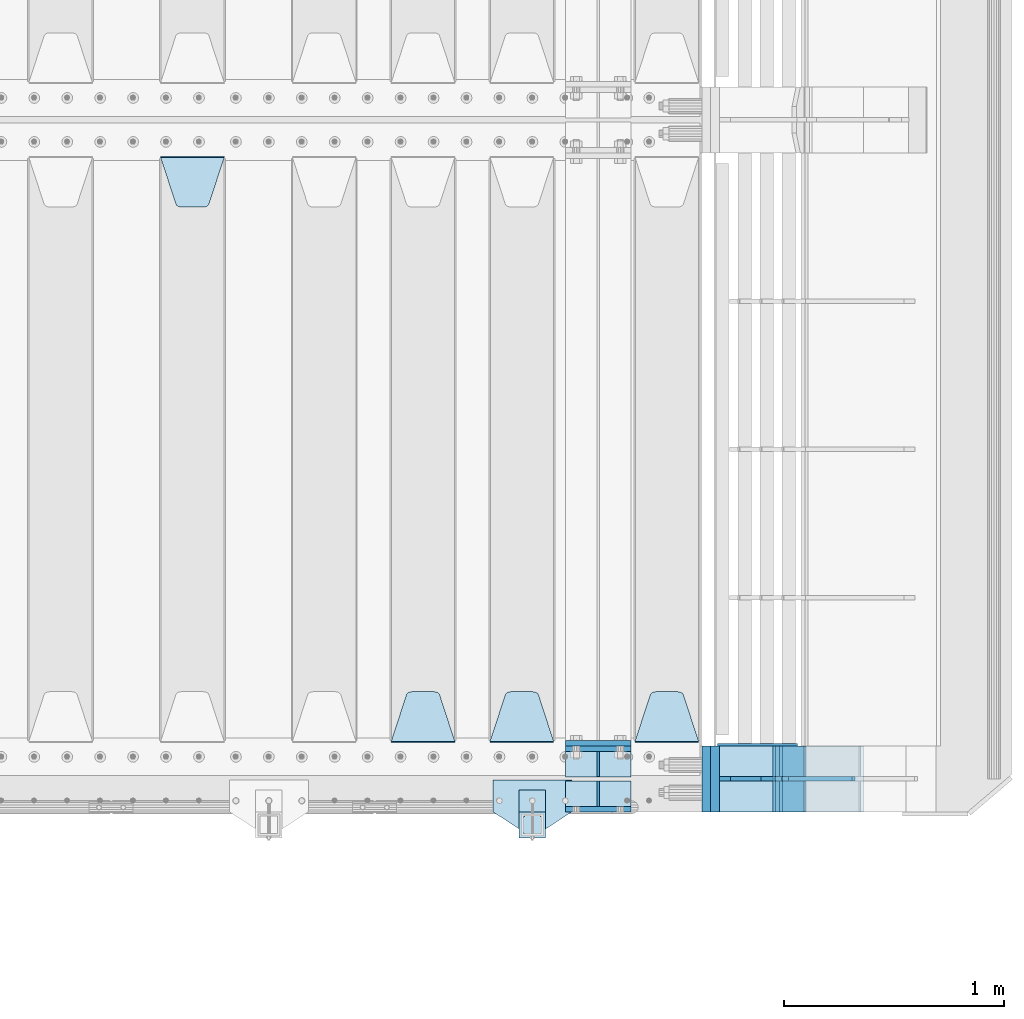
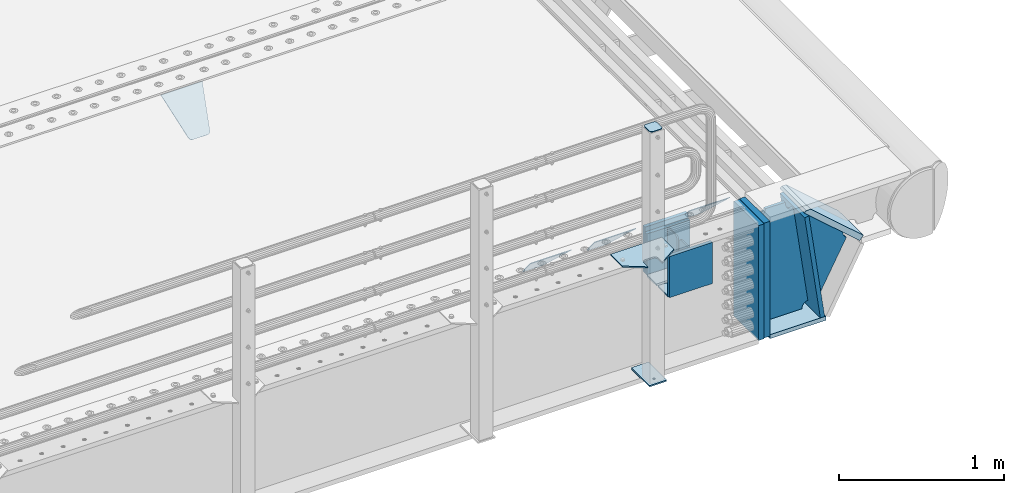
# One storey, part 219 of 242: 23 plates.
"""IFC2X3 building model written with IfcOpenShell, lengths in millimetres."""

from ifc_helpers import new_model, si_unit, frame, origin_with_axes, place, context, subcontext, project, spatial, faceted_brep, material, type_object, element, save


model = new_model("IFC2X3")

# Units and contexts
model_context = context("Model", 3, precision=1e-05, world=origin_with_axes())
body_context = subcontext(model_context, "Body", "Model", "MODEL_VIEW")
ifc_project = project(units=[si_unit("LENGTHUNIT", "METRE", prefix="MILLI"), si_unit("AREAUNIT", "SQUARE_METRE"), si_unit("VOLUMEUNIT", "CUBIC_METRE"), si_unit("MASSUNIT", "GRAM", prefix="KILO"), si_unit("TIMEUNIT", "SECOND"), si_unit("PLANEANGLEUNIT", "RADIAN"), si_unit("SOLIDANGLEUNIT", "STERADIAN"), si_unit("THERMODYNAMICTEMPERATUREUNIT", "DEGREE_CELSIUS"), si_unit("LUMINOUSINTENSITYUNIT", "LUMEN")], contexts=[model_context])

# Site, building, storey
site_placement = place(None, origin_with_axes())
site = spatial("IfcSite", under=ifc_project, at=site_placement, CompositionType="ELEMENT")
building_placement = place(site_placement, origin_with_axes())
building = spatial("IfcBuilding", under=site, at=building_placement, Name="Standard", CompositionType="ELEMENT")
storey_placement = place(building_placement, origin_with_axes())
storey = spatial("IfcBuildingStorey", under=building, at=storey_placement, Name="Undefined", CompositionType="ELEMENT", Elevation=0.0)

# Plates
ifc_material_1 = material(Name="STEEL/S355J2")
plate_type_1 = type_object("IfcPlateType", PredefinedType="NOTDEFINED")
plate_1_placement = place(storey_placement, frame((-22652.0, -24005.0, 5.00000000004911), z_axis=(0.0, -1.0, 0.0), x_axis=(-1.0, 0.0, 0.0)))
element("IfcPlate", 1, at=plate_1_placement, inside=storey, type_object=plate_type_1, material=ifc_material_1, context=body_context, shape_type="Brep", body=[
    faceted_brep([(0.0, -5.0, 0.0), (2.31396552408114e-06, -5.0, 145.0), (2.31396552408114e-06, 5.0, 145.0), (0.0, 5.0, 0.0), (130.0, -5.0, 230.0), (130.0, 5.0, 230.0), (130.0, -5.0, 180.0), (130.0, 5.0, 180.0), (130.48036798992, -5.0, 175.122741949595), (130.48036798992, 5.0, 175.122741949595), (131.903011687216, -5.0, 170.432914190871), (131.903011687216, 5.0, 170.432914190871), (134.213259692435, -5.0, 166.110744174512), (134.213259692435, 5.0, 166.110744174512), (137.322330470335, -5.0, 162.322330470335), (137.322330470335, 5.0, 162.322330470335), (141.110744174512, -5.0, 159.213259692435), (141.110744174512, 5.0, 159.213259692435), (145.432914190871, -5.0, 156.903011687216), (145.432914190871, 5.0, 156.903011687216), (150.122741949595, -5.0, 155.48036798992), (150.122741949595, 5.0, 155.48036798992), (155.0, -5.0, 155.0), (155.0, 5.0, 155.0), (205.0, -5.0, 155.0), (205.0, 5.0, 155.0), (209.877258050405, -5.0, 155.48036798992), (209.877258050405, 5.0, 155.48036798992), (214.567085809129, -5.0, 156.903011687216), (214.567085809129, 5.0, 156.903011687216), (218.889255825488, -5.0, 159.213259692435), (218.889255825488, 5.0, 159.213259692435), (222.677669529665, -5.0, 162.322330470335), (222.677669529665, 5.0, 162.322330470335), (225.786740307565, -5.0, 166.110744174512), (225.786740307565, 5.0, 166.110744174512), (228.096988312784, -5.0, 170.432914190871), (228.096988312784, 5.0, 170.432914190871), (229.51963201008, -5.0, 175.122741949595), (229.51963201008, 5.0, 175.122741949595), (230.0, -5.0, 180.0), (230.0, 5.0, 180.0), (230.0, -5.0, 230.0), (230.0, 5.0, 230.0), (360.0, -5.0, 145.0), (360.0, 5.0, 145.0), (360.0, -5.0, -7.27595761418343e-12), (360.0, 5.0, -7.27595761418343e-12)], [[[0, 1, 2, 3]], [[1, 4, 5, 2]], [[4, 6, 7, 5]], [[6, 8, 9, 7]], [[8, 10, 11, 9]], [[10, 12, 13, 11]], [[12, 14, 15, 13]], [[14, 16, 17, 15]], [[16, 18, 19, 17]], [[18, 20, 21, 19]], [[20, 22, 23, 21]], [[22, 24, 25, 23]], [[24, 26, 27, 25]], [[26, 28, 29, 27]], [[28, 30, 31, 29]], [[30, 32, 33, 31]], [[32, 34, 35, 33]], [[34, 36, 37, 35]], [[36, 38, 39, 37]], [[38, 40, 41, 39]], [[40, 42, 43, 41]], [[42, 44, 45, 43]], [[44, 46, 47, 45]], [[46, 0, 3, 47]], [[5, 7, 9, 11, 13, 15, 17, 19, 21, 23, 25, 27, 29, 31, 33, 35, 37, 39, 41, 43, 45, 47, 3, 2]], [[46, 44, 42, 40, 38, 36, 34, 32, 30, 28, 26, 24, 22, 20, 18, 16, 14, 12, 10, 8, 6, 4, 1, 0]]]),
])
plate_type_2 = type_object("IfcPlateType", PredefinedType="NOTDEFINED")
plate_2_placement = place(storey_placement, frame((-22772.0000000001, -24050.0000000002, -850.000000000002), z_axis=(0.0, -1.0, 0.0), x_axis=(-1.0, 0.0, 0.0)))
element("IfcPlate", 2, at=plate_2_placement, inside=storey, type_object=plate_type_2, material=ifc_material_1, context=body_context, shape_type="Brep", body=[
    faceted_brep([(53.6360389691836, -5.0, 176.363961030471), (53.6360389691836, 5.0, 176.363961030471), (59.9999999998618, 5.0, 178.999999999793), (59.9999999998618, -5.0, 178.999999999793), (66.3639610305399, 5.0, 176.363961030471), (66.3639610305399, -5.0, 176.363961030471), (68.9999999998618, 5.0, 169.999999999793), (68.9999999998618, -5.0, 169.999999999793), (66.3639610305399, 5.0, 163.636038969114), (66.3639610305399, -5.0, 163.636038969114), (59.9999999998618, 5.0, 160.999999999793), (59.9999999998618, -5.0, 160.999999999793), (53.6360389691836, 5.0, 163.636038969114), (53.6360389691836, -5.0, 163.636038969114), (50.9999999998618, 5.0, 169.999999999793), (50.9999999998618, -5.0, 169.999999999793), (120.0, -5.0, 0.0), (120.0, -5.0, 220.0), (0.0, -5.0, 220.0), (0.0, -5.0, 0.0), (0.0, 5.0, 0.0), (120.0, 5.0, 0.0), (120.0, 5.0, 220.0), (0.0, 5.0, 220.0)], [[[0, 1, 2, 3]], [[3, 2, 4, 5]], [[5, 4, 6, 7]], [[7, 6, 8, 9]], [[9, 8, 10, 11]], [[11, 10, 12, 13]], [[13, 12, 14, 15]], [[15, 14, 1, 0]], [[16, 17, 18, 19], [3, 5, 7, 9, 11, 13, 15, 0]], [[16, 19, 20, 21]], [[17, 16, 21, 22]], [[18, 17, 22, 23]], [[19, 18, 23, 20]], [[22, 21, 20, 23], [10, 8, 6, 4, 2, 1, 14, 12]]]),
])
plate_type_3 = type_object("IfcPlateType", PredefinedType="NOTDEFINED")
plate_3_placement = place(storey_placement, frame((-22876.0000000001, -24166.0000000002, 1012.50000000001), z_axis=(0.0, -1.0, 0.0), x_axis=(1.0, 0.0, 0.0)))
element("IfcPlate", 3, at=plate_3_placement, inside=storey, type_object=plate_type_3, material=ifc_material_1, context=body_context, shape_type="Brep", body=[
    faceted_brep([(0.0, -2.5, 19.0), (0.0, -2.5, 69.0), (0.0, 2.5, 69.0), (0.0, 2.5, 19.0), (0.476369668544066, -2.5, 73.2278977451715), (0.476369668544066, 2.5, 73.2278977451715), (1.88159150985302, -2.5, 77.2437910432345), (1.88159150985302, 2.5, 77.2437910432345), (4.14520183310742, -2.5, 80.8463062353148), (4.14520183310742, 2.5, 80.8463062353148), (7.15369376468516, -2.5, 83.8547981668926), (7.15369376468516, 2.5, 83.8547981668926), (10.7562089567655, -2.5, 86.118408490147), (10.7562089567655, 2.5, 86.118408490147), (14.7721022548285, -2.5, 87.5236303314559), (14.7721022548285, 2.5, 87.5236303314559), (19.0, -2.5, 88.0), (19.0, 2.5, 88.0), (69.0, -2.5, 88.0), (69.0, 2.5, 88.0), (73.2278977451715, -2.5, 87.5236303314559), (73.2278977451715, 2.5, 87.5236303314559), (77.2437910432345, -2.5, 86.118408490147), (77.2437910432345, 2.5, 86.118408490147), (80.8463062353148, -2.5, 83.8547981668926), (80.8463062353148, 2.5, 83.8547981668926), (83.8547981668926, -2.5, 80.8463062353148), (83.8547981668926, 2.5, 80.8463062353148), (86.118408490147, -2.5, 77.2437910432345), (86.118408490147, 2.5, 77.2437910432345), (87.5236303314559, -2.5, 73.2278977451715), (87.5236303314559, 2.5, 73.2278977451715), (88.0, -2.5, 69.0), (88.0, 2.5, 69.0), (88.0, -2.5, 19.0), (88.0, 2.5, 19.0), (87.5236303314559, -2.5, 14.7721022548285), (87.5236303314559, 2.5, 14.7721022548285), (86.118408490147, -2.5, 10.7562089567655), (86.118408490147, 2.5, 10.7562089567655), (83.8547981668926, -2.5, 7.15369376468516), (83.8547981668926, 2.5, 7.15369376468516), (80.8463062353148, -2.5, 4.14520183310742), (80.8463062353148, 2.5, 4.14520183310742), (77.2437910432345, -2.5, 1.88159150985302), (77.2437910432345, 2.5, 1.88159150985302), (73.2278977451715, -2.5, 0.476369668544066), (73.2278977451715, 2.5, 0.476369668544066), (69.0, -2.5, 0.0), (69.0, 2.5, 0.0), (19.0, -2.5, 0.0), (19.0, 2.5, 0.0), (14.7721022548285, -2.5, 0.476369668544066), (14.7721022548285, 2.5, 0.476369668544066), (10.7562089567655, -2.5, 1.88159150985302), (10.7562089567655, 2.5, 1.88159150985302), (7.15369376468516, -2.5, 4.14520183310742), (7.15369376468516, 2.5, 4.14520183310742), (4.14520183310742, -2.5, 7.15369376468516), (4.14520183310742, 2.5, 7.15369376468516), (1.88159150985302, -2.5, 10.7562089567655), (1.88159150985302, 2.5, 10.7562089567655), (0.476369668544066, -2.5, 14.7721022548285), (0.476369668544066, 2.5, 14.7721022548285)], [[[0, 1, 2, 3]], [[1, 4, 5, 2]], [[4, 6, 7, 5]], [[6, 8, 9, 7]], [[8, 10, 11, 9]], [[10, 12, 13, 11]], [[12, 14, 15, 13]], [[14, 16, 17, 15]], [[16, 18, 19, 17]], [[18, 20, 21, 19]], [[20, 22, 23, 21]], [[22, 24, 25, 23]], [[24, 26, 27, 25]], [[26, 28, 29, 27]], [[28, 30, 31, 29]], [[30, 32, 33, 31]], [[32, 34, 35, 33]], [[34, 36, 37, 35]], [[36, 38, 39, 37]], [[38, 40, 41, 39]], [[40, 42, 43, 41]], [[42, 44, 45, 43]], [[44, 46, 47, 45]], [[46, 48, 49, 47]], [[48, 50, 51, 49]], [[50, 52, 53, 51]], [[52, 54, 55, 53]], [[54, 56, 57, 55]], [[56, 58, 59, 57]], [[58, 60, 61, 59]], [[60, 62, 63, 61]], [[62, 0, 3, 63]], [[5, 7, 9, 11, 13, 15, 17, 19, 21, 23, 25, 27, 29, 31, 33, 35, 37, 39, 41, 43, 45, 47, 49, 51, 53, 55, 57, 59, 61, 63, 3, 2]], [[62, 60, 58, 56, 54, 52, 50, 48, 46, 44, 42, 40, 38, 36, 34, 32, 30, 28, 26, 24, 22, 20, 18, 16, 14, 12, 10, 8, 6, 4, 1, 0]]]),
])
plate_type_4 = type_object("IfcPlateType", PredefinedType="NOTDEFINED")
plate_4_placement = place(storey_placement, frame((-22772.0000000001, -24050.0000000002, -857.500000000002), z_axis=(0.0, -1.0, 0.0), x_axis=(-1.0, 0.0, 0.0)))
element("IfcPlate", 4, at=plate_4_placement, inside=storey, type_object=plate_type_4, material=ifc_material_1, context=body_context, shape_type="Brep", body=[
    faceted_brep([(0.0, -2.5, 0.0), (0.0, -2.5, 100.0), (0.0, 2.5, 100.0), (0.0, 2.5, 0.0), (120.0, -2.5, 100.0), (120.0, 2.5, 100.0), (120.0, -2.5, 0.0), (120.0, 2.5, 0.0)], [[[0, 1, 2, 3]], [[1, 4, 5, 2]], [[4, 6, 7, 5]], [[6, 0, 3, 7]], [[5, 7, 3, 2]], [[6, 4, 1, 0]]]),
])
ifc_material_2 = material(Name="STEEL/S355N")
plate_type_5 = type_object("IfcPlateType", PredefinedType="NOTDEFINED")
plate_5_placement = place(storey_placement, frame((-22682.0, -23837.5, -340.000000000044), z_axis=(0.0, 0.0, 1.0), x_axis=(1.0, 0.0, 0.0)))
element("IfcPlate", 5, at=plate_5_placement, inside=storey, type_object=plate_type_5, material=ifc_material_2, context=body_context, shape_type="Brep", body=[
    faceted_brep([(0.0, -12.5, 0.0), (9.27684595808387e-10, -12.5, 340.0), (9.27684595808387e-10, 12.5, 340.0), (0.0, 12.5, 0.0), (300.0, -12.5, 340.0), (300.0, 12.5, 340.0), (300.0, -12.5, 0.0), (300.0, 12.5, 0.0)], [[[0, 1, 2, 3]], [[1, 4, 5, 2]], [[4, 6, 7, 5]], [[6, 0, 3, 7]], [[5, 7, 3, 2]], [[6, 4, 1, 0]]]),
])
for number, where, z_axis, x_axis in (
    (6, (-22682.0, -24137.5, -339.99999999999), (0.0, 0.0, 1.0), (1.0, 0.0, 0.0)),
    (7, (-22682.0, -23862.5, -339.99999999999), (0.0, 0.0, 1.0), (1.0, 0.0, 0.0)),
):
    element("IfcPlate", number, at=place(storey_placement, frame(where, z_axis=z_axis, x_axis=x_axis)), inside=storey, type_object=plate_type_5, material=ifc_material_2, context=body_context, shape_type="Brep", body=[
        faceted_brep([(0.0, -12.5, 0.0), (0.0, -12.5, 305.0), (0.0, 12.5, 305.0), (0.0, 12.5, 0.0), (300.0, -12.5, 305.0), (300.0, 12.5, 305.0), (300.0, -12.5, 0.0), (300.0, 12.5, 0.0)], [[[0, 1, 2, 3]], [[1, 4, 5, 2]], [[4, 6, 7, 5]], [[6, 0, 3, 7]], [[5, 7, 3, 2]], [[6, 4, 1, 0]]]),
    ])
plate_type_6 = type_object("IfcPlateType", PredefinedType="NOTDEFINED")
plate_6_placement = place(storey_placement, frame((-22075.0, -23831.767766953, -1.76776695296758), z_axis=(0.0, 0.707106781186547, -0.707106781186548), x_axis=(-1.0, 0.0, 0.0)))
element("IfcPlate", 8, at=plate_6_placement, inside=storey, type_object=plate_type_6, material=ifc_material_2, context=body_context, shape_type="Brep", body=[
    faceted_brep([(0.0, -2.5, 0.0), (69.345504679477, -2.50000000000182, 300.171731424829), (69.345504679477, 2.5, 300.171731424829), (0.0, 2.5, 0.0), (70.9274061199576, -2.5, 304.897442415398), (70.9274061199576, 2.5, 304.897442415398), (73.3818627772307, -2.5, 309.234538108525), (73.3818627772307, 2.50000000000182, 309.234538108529), (76.6187032999551, -2.5, 313.023683126101), (76.6187032999551, 2.50000000000182, 313.023683126103), (80.5190132704993, -2.5, 316.12567259537), (80.5190132704993, 2.5, 316.12567259537), (84.9395038596849, -2.5, 318.426546230474), (84.9395038596849, 2.50000000000182, 318.426546230476), (89.7177759439219, -2.49999999999818, 319.841774983273), (89.7177759439219, 2.50000000000182, 319.841774983273), (94.678286292652, -2.5, 320.319366455076), (94.678286292652, 2.5, 320.319366455076), (195.321713707348, -2.5, 320.319366455076), (195.321713707348, 2.5, 320.319366455076), (200.282224056078, -2.5, 319.841774983272), (200.282224056078, 2.50000000000182, 319.841774983273), (205.060496140315, -2.5, 318.426546230474), (205.060496140315, 2.49999999999818, 318.426546230474), (209.480986729501, -2.49999999999818, 316.12567259537), (209.480986729501, 2.5, 316.12567259537), (213.381296700045, -2.5, 313.023683126101), (213.381296700045, 2.49999999999818, 313.023683126101), (216.618137222769, -2.5, 309.234538108525), (216.618137222769, 2.5, 309.234538108523), (219.072593880042, -2.49999999999818, 304.897442415398), (219.072593880042, 2.50000000000182, 304.897442415398), (220.654495320523, -2.50000000000182, 300.171731424829), (220.654495320523, 2.5, 300.171731424829), (290.0, -2.5, 0.0), (290.0, 2.5, -1.81898940354586e-12)], [[[0, 1, 2, 3]], [[1, 4, 5, 2]], [[4, 6, 7, 5]], [[6, 8, 9, 7]], [[8, 10, 11, 9]], [[10, 12, 13, 11]], [[12, 14, 15, 13]], [[14, 16, 17, 15]], [[16, 18, 19, 17]], [[18, 20, 21, 19]], [[20, 22, 23, 21]], [[22, 24, 25, 23]], [[24, 26, 27, 25]], [[26, 28, 29, 27]], [[28, 30, 31, 29]], [[30, 32, 33, 31]], [[32, 34, 35, 33]], [[34, 0, 3, 35]], [[5, 7, 9, 11, 13, 15, 17, 19, 21, 23, 25, 27, 29, 31, 33, 35, 3, 2]], [[34, 32, 30, 28, 26, 24, 22, 20, 18, 16, 14, 12, 10, 8, 6, 4, 1, 0]]]),
])
plate_7_placement = place(storey_placement, frame((-22735.0, -23831.767766953, -1.76776695296758), z_axis=(0.0, 0.707106781186547, -0.707106781186548), x_axis=(-1.0, 0.0, 0.0)))
element("IfcPlate", 9, at=plate_7_placement, inside=storey, type_object=plate_type_6, material=ifc_material_2, context=body_context, shape_type="Brep", body=[
    faceted_brep([(0.0, -2.5, 0.0), (69.345504679477, -2.50000000000182, 300.171731424829), (69.345504679477, 2.5, 300.171731424829), (0.0, 2.5, 0.0), (70.9274061199576, -2.5, 304.897442415398), (70.9274061199576, 2.5, 304.897442415398), (73.3818627772307, -2.5, 309.234538108525), (73.3818627772307, 2.50000000000182, 309.234538108529), (76.6187032999551, -2.5, 313.023683126101), (76.6187032999551, 2.50000000000182, 313.023683126103), (80.5190132704993, -2.5, 316.12567259537), (80.5190132704993, 2.5, 316.12567259537), (84.9395038596849, -2.5, 318.426546230474), (84.9395038596849, 2.50000000000182, 318.426546230476), (89.7177759439219, -2.49999999999818, 319.841774983273), (89.7177759439219, 2.50000000000182, 319.841774983273), (94.678286292652, -2.5, 320.319366455076), (94.678286292652, 2.5, 320.319366455076), (195.321713707348, -2.5, 320.319366455076), (195.321713707348, 2.5, 320.319366455076), (200.282224056078, -2.5, 319.841774983272), (200.282224056078, 2.50000000000182, 319.841774983273), (205.060496140315, -2.5, 318.426546230474), (205.060496140315, 2.49999999999818, 318.426546230474), (209.480986729501, -2.49999999999818, 316.12567259537), (209.480986729501, 2.5, 316.12567259537), (213.381296700045, -2.5, 313.023683126101), (213.381296700045, 2.49999999999818, 313.023683126101), (216.618137222769, -2.5, 309.234538108525), (216.618137222769, 2.5, 309.234538108523), (219.072593880042, -2.49999999999818, 304.897442415398), (219.072593880042, 2.50000000000182, 304.897442415398), (220.654495320523, -2.50000000000182, 300.171731424829), (220.654495320523, 2.5, 300.171731424829), (290.0, -2.5, 0.0), (290.0, 2.5, -1.81898940354586e-12)], [[[0, 1, 2, 3]], [[1, 4, 5, 2]], [[4, 6, 7, 5]], [[6, 8, 9, 7]], [[8, 10, 11, 9]], [[10, 12, 13, 11]], [[12, 14, 15, 13]], [[14, 16, 17, 15]], [[16, 18, 19, 17]], [[18, 20, 21, 19]], [[20, 22, 23, 21]], [[22, 24, 25, 23]], [[24, 26, 27, 25]], [[26, 28, 29, 27]], [[28, 30, 31, 29]], [[30, 32, 33, 31]], [[32, 34, 35, 33]], [[34, 0, 3, 35]], [[5, 7, 9, 11, 13, 15, 17, 19, 21, 23, 25, 27, 29, 31, 33, 35, 3, 2]], [[34, 32, 30, 28, 26, 24, 22, 20, 18, 16, 14, 12, 10, 8, 6, 4, 1, 0]]]),
])
plate_8_placement = place(storey_placement, frame((-23185.0, -23831.767766953, -1.76776695296758), z_axis=(0.0, 0.707106781186547, -0.707106781186548), x_axis=(-1.0, 0.0, 0.0)))
element("IfcPlate", 10, at=plate_8_placement, inside=storey, type_object=plate_type_6, material=ifc_material_2, context=body_context, shape_type="Brep", body=[
    faceted_brep([(0.0, -2.5, 0.0), (69.345504679477, -2.50000000000182, 300.171731424829), (69.345504679477, 2.5, 300.171731424829), (0.0, 2.5, 0.0), (70.9274061199576, -2.5, 304.897442415398), (70.9274061199576, 2.5, 304.897442415398), (73.3818627772307, -2.5, 309.234538108525), (73.3818627772307, 2.50000000000182, 309.234538108529), (76.6187032999551, -2.5, 313.023683126101), (76.6187032999551, 2.50000000000182, 313.023683126103), (80.5190132704993, -2.5, 316.12567259537), (80.5190132704993, 2.5, 316.12567259537), (84.9395038596849, -2.5, 318.426546230474), (84.9395038596849, 2.50000000000182, 318.426546230476), (89.7177759439219, -2.49999999999818, 319.841774983273), (89.7177759439219, 2.50000000000182, 319.841774983273), (94.678286292652, -2.5, 320.319366455076), (94.678286292652, 2.5, 320.319366455076), (195.321713707348, -2.5, 320.319366455076), (195.321713707348, 2.5, 320.319366455076), (200.282224056078, -2.5, 319.841774983272), (200.282224056078, 2.50000000000182, 319.841774983273), (205.060496140315, -2.5, 318.426546230474), (205.060496140315, 2.49999999999818, 318.426546230474), (209.480986729501, -2.49999999999818, 316.12567259537), (209.480986729501, 2.5, 316.12567259537), (213.381296700045, -2.5, 313.023683126101), (213.381296700045, 2.49999999999818, 313.023683126101), (216.618137222769, -2.5, 309.234538108525), (216.618137222769, 2.5, 309.234538108523), (219.072593880042, -2.49999999999818, 304.897442415398), (219.072593880042, 2.50000000000182, 304.897442415398), (220.654495320523, -2.50000000000182, 300.171731424829), (220.654495320523, 2.5, 300.171731424829), (290.0, -2.5, 0.0), (290.0, 2.5, -1.81898940354586e-12)], [[[0, 1, 2, 3]], [[1, 4, 5, 2]], [[4, 6, 7, 5]], [[6, 8, 9, 7]], [[8, 10, 11, 9]], [[10, 12, 13, 11]], [[12, 14, 15, 13]], [[14, 16, 17, 15]], [[16, 18, 19, 17]], [[18, 20, 21, 19]], [[20, 22, 23, 21]], [[22, 24, 25, 23]], [[24, 26, 27, 25]], [[26, 28, 29, 27]], [[28, 30, 31, 29]], [[30, 32, 33, 31]], [[32, 34, 35, 33]], [[34, 0, 3, 35]], [[5, 7, 9, 11, 13, 15, 17, 19, 21, 23, 25, 27, 29, 31, 33, 35, 3, 2]], [[34, 32, 30, 28, 26, 24, 22, 20, 18, 16, 14, 12, 10, 8, 6, 4, 1, 0]]]),
])
plate_9_placement = place(storey_placement, frame((-24525.0, -21168.232233044, -1.76776695296576), z_axis=(0.0, -0.707106781186547, -0.707106781186548), x_axis=(1.0, 0.0, 0.0)))
element("IfcPlate", 11, at=plate_9_placement, inside=storey, type_object=plate_type_6, material=ifc_material_2, context=body_context, shape_type="Brep", body=[
    faceted_brep([(0.0, -2.5, 0.0), (69.345504679477, -2.50000000000182, 300.171731424829), (69.345504679477, 2.5, 300.171731424829), (0.0, 2.5, 0.0), (70.9274061199576, -2.5, 304.897442415398), (70.9274061199576, 2.5, 304.897442415398), (73.3818627772307, -2.5, 309.234538108525), (73.3818627772307, 2.50000000000182, 309.234538108529), (76.6187032999551, -2.5, 313.023683126101), (76.6187032999551, 2.50000000000182, 313.023683126103), (80.5190132704993, -2.5, 316.12567259537), (80.5190132704993, 2.5, 316.12567259537), (84.9395038596849, -2.5, 318.426546230474), (84.9395038596849, 2.50000000000182, 318.426546230476), (89.7177759439219, -2.49999999999818, 319.841774983273), (89.7177759439219, 2.50000000000182, 319.841774983273), (94.678286292652, -2.5, 320.319366455076), (94.678286292652, 2.5, 320.319366455076), (195.321713707348, -2.5, 320.319366455076), (195.321713707348, 2.5, 320.319366455076), (200.282224056078, -2.5, 319.841774983272), (200.282224056078, 2.50000000000182, 319.841774983273), (205.060496140315, -2.5, 318.426546230474), (205.060496140315, 2.49999999999818, 318.426546230474), (209.480986729501, -2.49999999999818, 316.12567259537), (209.480986729501, 2.5, 316.12567259537), (213.381296700045, -2.5, 313.023683126101), (213.381296700045, 2.49999999999818, 313.023683126101), (216.618137222769, -2.5, 309.234538108525), (216.618137222769, 2.5, 309.234538108523), (219.072593880042, -2.49999999999818, 304.897442415398), (219.072593880042, 2.50000000000182, 304.897442415398), (220.654495320523, -2.50000000000182, 300.171731424829), (220.654495320523, 2.5, 300.171731424829), (290.0, -2.5, 0.0), (290.0, 2.5, -1.81898940354586e-12)], [[[0, 1, 2, 3]], [[1, 4, 5, 2]], [[4, 6, 7, 5]], [[6, 8, 9, 7]], [[8, 10, 11, 9]], [[10, 12, 13, 11]], [[12, 14, 15, 13]], [[14, 16, 17, 15]], [[16, 18, 19, 17]], [[18, 20, 21, 19]], [[20, 22, 23, 21]], [[22, 24, 25, 23]], [[24, 26, 27, 25]], [[26, 28, 29, 27]], [[28, 30, 31, 29]], [[30, 32, 33, 31]], [[32, 34, 35, 33]], [[34, 0, 3, 35]], [[5, 7, 9, 11, 13, 15, 17, 19, 21, 23, 25, 27, 29, 31, 33, 35, 3, 2]], [[34, 32, 30, 28, 26, 24, 22, 20, 18, 16, 14, 12, 10, 8, 6, 4, 1, 0]]]),
])
plate_type_7 = type_object("IfcPlateType", PredefinedType="NOTDEFINED")
plate_10_placement = place(storey_placement, frame((-21587.0011701109, -23850.0, -875.000000002935), z_axis=(0.0, -1.0, 0.0), x_axis=(-1.0, 0.0, 0.0)))
element("IfcPlate", 12, at=plate_10_placement, inside=storey, type_object=plate_type_7, material=ifc_material_2, context=body_context, shape_type="Brep", body=[
    faceted_brep([(0.0, -15.0, 0.0), (0.0, -15.0, 300.0), (0.0, 15.0, 300.0), (0.0, 15.0, 0.0), (393.0, -15.0, 300.0), (393.0, 15.0, 300.0), (393.0, -15.0, 0.0), (393.0, 15.0, 0.0)], [[[0, 1, 2, 3]], [[1, 4, 5, 2]], [[4, 6, 7, 5]], [[6, 0, 3, 7]], [[5, 7, 3, 2]], [[6, 4, 1, 0]]]),
])
plate_11_placement = place(storey_placement, frame((-21610.8519322773, -23849.999999999, -862.083788727077), z_axis=(-0.139173011053008, 0.0, 0.990268081377179), x_axis=(0.0, -1.0, 0.0)))
element("IfcPlate", 13, at=plate_11_placement, inside=storey, type_object=plate_type_7, material=ifc_material_2, context=body_context, shape_type="Brep", body=[
    faceted_brep([(1.00408215075731e-09, 14.9994702460535, -0.00376939767375006), (300.0, 15.0, 0.0), (300.0, -15.0, 4.21237841386846), (0.0, -15.0, 4.21237841386846), (0.0, -14.9999999999964, 792.0), (300.0, -14.9999999999964, 792.0), (300.0, 15.0, 792.0), (0.0, 15.0, 792.0)], [[[0, 1, 2, 3]], [[4, 5, 6, 7]], [[4, 7, 0, 3]], [[5, 4, 3, 2]], [[6, 5, 2, 1]], [[7, 6, 1, 0]]]),
])
plate_type_8 = type_object("IfcPlateType", PredefinedType="NOTDEFINED")
plate_12_placement = place(storey_placement, frame((-21338.0011701102, -23850.0000000008, -367.999999998984), z_axis=(-0.752989422949573, 0.0, 0.658032619955933), x_axis=(0.0, -1.0, 0.0)))
element("IfcPlate", 14, at=plate_12_placement, inside=storey, type_object=plate_type_8, material=ifc_material_2, context=body_context, shape_type="Brep", body=[
    faceted_brep([(-8.11269273981452e-10, 20.0, 490.766265601622), (0.0, -0.30381125094209, 514.0), (300.0, -0.30381125094209, 514.0), (300.0, 20.0, 490.766265601622), (300.0, -20.0, 3.63797880709171e-12), (300.0, -20.0000000000018, 514.000000000002), (0.0, -20.0000000000018, 514.000000000002), (0.0, -20.0, 0.0), (0.0, 20.0, 0.0), (300.0, 20.0, 3.63797880709171e-12)], [[[0, 1, 2, 3]], [[4, 5, 6, 7]], [[4, 7, 8, 9]], [[9, 8, 0, 3]], [[5, 4, 9, 3, 2]], [[6, 5, 2, 1]], [[8, 7, 6, 1, 0]]]),
])
ifc_material_3 = material()
for number, where, z_axis, x_axis in (
    (15, (-22000.0011701093, -23850.0, -869.999999999685), (0.0, 0.0, 1.0), (0.0, -1.0, 0.0)),
    (16, (-22040.0, -23850.0, -875.0), (0.0, 0.0, 1.0), (0.0, -1.0, 0.0)),
):
    element("IfcPlate", number, at=place(storey_placement, frame(where, z_axis=z_axis, x_axis=x_axis)), inside=storey, type_object=plate_type_8, material=ifc_material_3, context=body_context, shape_type="Brep", body=[
        faceted_brep([(0.0, -20.0, 0.0), (9.5367431640625e-07, -20.0, 850.0), (9.5367431640625e-07, 20.0, 850.0), (0.0, 20.0, 0.0), (300.0, -20.0, 850.0), (300.0, 20.0, 850.0), (300.0, -20.0, 3.63797880709171e-12), (300.0, 20.0, 3.63797880709171e-12)], [[[0, 1, 2, 3]], [[1, 4, 5, 2]], [[4, 6, 7, 5]], [[6, 0, 3, 7]], [[5, 7, 3, 2]], [[6, 4, 1, 0]]]),
    ])
plate_type_9 = type_object("IfcPlateType", PredefinedType="NOTDEFINED")
plate_13_placement = place(storey_placement, frame((-21338.9974314966, -23999.999999999, -393.996688204089), z_axis=(-0.658066357015091, 0.0, -0.752959939017267), x_axis=(-0.752959939017267, 0.0, 0.658066357015091)))
element("IfcPlate", 17, at=plate_13_placement, inside=storey, type_object=plate_type_9, material=ifc_material_2, context=body_context, shape_type="Brep", body=[
    faceted_brep([(-11.3595226159559, -10.0, 48.6925173505915), (-112.015767301033, -10.0, 480.154833723631), (-112.015767301033, 10.0, 480.154833723631), (-11.3595226159559, 10.0, 48.6925173505915), (-104.567323293637, -10.0, 482.519601382544), (-104.567323293637, 10.0, 482.519601382544), (-97.5783311599953, -10.0, 486.016090073757), (-97.5783311599953, 10.0, 486.016090073757), (-91.2195220373778, -10.0, 490.558885551658), (-91.2195220373778, 10.0, 490.558885551658), (-85.6462325884204, -10.0, 496.037013784005), (-85.6462325884204, 10.0, 496.037013784005), (447.024482710496, -10.0, 32.8103372896385), (447.024482710496, 10.0, 32.8103372896385), (441.786973010398, -10.0, 25.570962393731), (441.786973010398, 10.0, 25.570962393731), (437.921644570131, -10.0, 17.5149526624173), (437.921644570131, 10.0, 17.5149526624173), (435.551940606498, -10.0, 8.89958500531975), (435.551940606498, 10.0, 8.89958500531975), (434.753540039064, -10.0, -5.16592990607023e-10), (434.753540039064, 10.0, -5.16592990607023e-10), (50.0, -10.0, 0.0), (50.0, 10.0, 0.0), (47.7668538974267, -10.0, 14.7759151575192), (47.7668538974267, 10.0, 14.7759151575192), (41.2668932502838, -10.0, 28.2319592212461), (41.2668932502838, 10.0, 28.2319592212461), (31.0807325300193, -10.0, 39.1661596968297), (31.0807325300193, 10.0, 39.1661596968297), (18.1182591411507, -10.0, 46.6018098971963), (18.1182591411507, 10.0, 46.6018098971963), (3.5373569608073, -10.0, 49.8747140917349), (3.5373569608073, 10.0, 49.8747140917349)], [[[0, 1, 2, 3]], [[1, 4, 5, 2]], [[4, 6, 7, 5]], [[6, 8, 9, 7]], [[8, 10, 11, 9]], [[10, 12, 13, 11]], [[12, 14, 15, 13]], [[14, 16, 17, 15]], [[16, 18, 19, 17]], [[18, 20, 21, 19]], [[20, 22, 23, 21]], [[22, 24, 25, 23]], [[24, 26, 27, 25]], [[26, 28, 29, 27]], [[28, 30, 31, 29]], [[30, 32, 33, 31]], [[32, 0, 3, 33]], [[5, 7, 9, 11, 13, 15, 17, 19, 21, 23, 25, 27, 29, 31, 33, 3, 2]], [[32, 30, 28, 26, 24, 22, 20, 18, 16, 14, 12, 10, 8, 6, 4, 1, 0]]]),
])
plate_type_10 = type_object("IfcPlateType", PredefinedType="NOTDEFINED")
plate_14_placement = place(storey_placement, frame((-21741.0011701109, -24000.0, -30.0000000029351), z_axis=(0.0, 0.0, -1.0), x_axis=(-1.0, 0.0, 0.0)))
element("IfcPlate", 18, at=plate_14_placement, inside=storey, type_object=plate_type_10, material=ifc_material_2, context=body_context, shape_type="Brep", body=[
    faceted_brep([(-9.00602409638668, -10.0, 65.0), (-108.137843376921, -10.0, 780.473130459514), (-108.137843376921, 10.0, 780.473130459514), (-9.00602409638668, 10.0, 65.0), (-94.4157884488377, -10.0, 784.433672138112), (-94.4157884488377, 10.0, 784.433672138112), (-82.3732461236723, -10.0, 792.112074067144), (-82.3732461236723, 10.0, 792.112074067144), (-72.9927947992364, -10.0, 802.881837982249), (-72.9927947992364, 10.0, 802.881837982249), (-67.0398068183713, -10.0, 815.864234368775), (-67.0398068183713, 10.0, 815.864234368775), (-65.0, -10.0, 830.0), (-65.0, 10.0, 830.0), (189.0, -10.0, 830.0), (189.0, 10.0, 830.0), (191.447174185243, -10.0, 814.549150281253), (191.447174185243, 10.0, 814.549150281253), (198.549150281251, -10.0, 800.610737385376), (198.549150281251, 10.0, 800.610737385376), (209.610737385377, -10.0, 789.549150281253), (209.610737385377, 10.0, 789.549150281253), (223.549150281251, -10.0, 782.447174185242), (223.549150281251, 10.0, 782.447174185242), (239.0, -10.0, 780.0), (239.0, 10.0, 780.0), (239.0, -10.0, 50.0), (239.0, 10.0, 50.0), (223.549150281251, -10.0, 47.5528258147577), (223.549150281251, 10.0, 47.5528258147577), (209.610737385377, -10.0, 40.4508497187474), (209.610737385377, 10.0, 40.4508497187474), (198.549150281251, -10.0, 29.3892626146237), (198.549150281251, 10.0, 29.3892626146237), (191.447174185243, -10.0, 15.4508497187474), (191.447174185243, 10.0, 15.4508497187474), (189.0, -10.0, 0.0), (189.0, 10.0, 0.0), (50.4776502774184, -10.0, 0.0), (50.4776502774184, 10.0, 0.0), (47.3830020671812, -10.0, 22.3352870825933), (47.3830020671812, 10.0, 22.3352870825933), (42.8384615202776, -10.0, 37.3040735979326), (42.8384615202776, 10.0, 37.3040735979326), (33.8907372011709, -10.0, 50.1358952937587), (33.8907372011709, 10.0, 50.1358952937587), (21.4156947086703, -10.0, 59.5746840579253), (21.4156947086703, 10.0, 59.5746840579253), (6.63447812067898, -10.0, 64.6965054822873), (6.63447812067898, 10.0, 64.6965054822873)], [[[0, 1, 2, 3]], [[1, 4, 5, 2]], [[4, 6, 7, 5]], [[6, 8, 9, 7]], [[8, 10, 11, 9]], [[10, 12, 13, 11]], [[12, 14, 15, 13]], [[14, 16, 17, 15]], [[16, 18, 19, 17]], [[18, 20, 21, 19]], [[20, 22, 23, 21]], [[22, 24, 25, 23]], [[24, 26, 27, 25]], [[26, 28, 29, 27]], [[28, 30, 31, 29]], [[30, 32, 33, 31]], [[32, 34, 35, 33]], [[34, 36, 37, 35]], [[36, 38, 39, 37]], [[38, 40, 41, 39]], [[40, 42, 43, 41]], [[42, 44, 45, 43]], [[44, 46, 47, 45]], [[46, 48, 49, 47]], [[48, 0, 3, 49]], [[5, 7, 9, 11, 13, 15, 17, 19, 21, 23, 25, 27, 29, 31, 33, 35, 37, 39, 41, 43, 45, 47, 49, 3, 2]], [[48, 46, 44, 42, 40, 38, 36, 34, 32, 30, 28, 26, 24, 22, 20, 18, 16, 14, 12, 10, 8, 6, 4, 1, 0]]]),
])
plate_type_11 = type_object("IfcPlateType", PredefinedType="NOTDEFINED")
plate_15_placement = place(storey_placement, frame((-21625.001170099, -23845.0, -249.999999999564), z_axis=(-1.0, 0.0, 0.0), x_axis=(0.0, 0.0, 1.0)))
element("IfcPlate", 19, at=plate_15_placement, inside=storey, type_object=plate_type_11, material=ifc_material_2, context=body_context, shape_type="Brep", body=[
    faceted_brep([(0.0, -5.0, 0.0), (0.0, -5.0, 365.0), (0.0, 5.0, 365.0), (0.0, 5.0, 0.0), (80.0, -5.0, 365.0), (80.0, 5.0, 365.0), (80.0, -5.0, 0.0), (80.0, 5.0, 0.0)], [[[0, 1, 2, 3]], [[1, 4, 5, 2]], [[4, 6, 7, 5]], [[6, 0, 3, 7]], [[5, 7, 3, 2]], [[6, 4, 1, 0]]]),
])
plate_type_12 = type_object("IfcPlateType", PredefinedType="NOTDEFINED")
for number, where, z_axis, x_axis in (
    (20, (-22682.0, -23990.75, -342.99999999999), (0.0, 1.0, 0.0), (1.0, 0.0, 0.0)),
    (21, (-22682.0, -24009.25, -342.99999999999), (0.0, -1.0, 0.0), (1.0, 0.0, 0.0)),
):
    element("IfcPlate", number, at=place(storey_placement, frame(where, z_axis=z_axis, x_axis=x_axis)), inside=storey, type_object=plate_type_12, material=ifc_material_2, context=body_context, shape_type="Brep", body=[
        faceted_brep([(0.0, -7.0, 0.0), (0.0, -7.0, 115.75), (0.0, 7.0, 115.75), (0.0, 7.0, 0.0), (300.0, -7.0, 115.75), (300.0, 7.0, 115.75), (300.0, -7.0, 0.0), (300.0, 7.0, 0.0)], [[[0, 1, 2, 3]], [[1, 4, 5, 2]], [[4, 6, 7, 5]], [[6, 0, 3, 7]], [[5, 7, 3, 2]], [[6, 4, 1, 0]]]),
    ])
plate_type_13 = type_object("IfcPlateType", PredefinedType="NOTDEFINED")
for number, where, z_axis, x_axis in (
    (22, (-22532.0, -23990.75, -34.9999999999899), (0.0, 0.0, -1.0), (0.0, 1.0, 0.0)),
    (23, (-22532.0, -24009.25, -34.9999999999899), (0.0, 0.0, -1.0), (0.0, -1.0, 0.0)),
):
    element("IfcPlate", number, at=place(storey_placement, frame(where, z_axis=z_axis, x_axis=x_axis)), inside=storey, type_object=plate_type_13, material=ifc_material_2, context=body_context, shape_type="Brep", body=[
        faceted_brep([(0.0, -5.0, 30.0), (0.0, -5.0, 301.0), (0.0, 5.0, 301.0), (0.0, 5.0, 30.0), (115.75, -5.0, 301.0), (115.75, 5.0, 301.0), (115.75, -5.0, 0.0), (115.75, 5.0, 0.0), (30.0, -5.0, 0.0), (30.0, 5.0, 0.0), (24.7905546699913, -5.0, 0.455767409633758), (24.7905546699913, 5.0, 0.455767409633758), (19.7393957002314, -5.0, 1.80922137642275), (19.7393957002314, 5.0, 1.80922137642275), (15.0, -5.0, 4.01923788646684), (15.0, 5.0, 4.01923788646684), (10.7163717094045, -5.0, 7.01866670643066), (10.7163717094045, 5.0, 7.01866670643066), (7.01866670642994, -5.0, 10.7163717094038), (7.01866670642994, 5.0, 10.7163717094038), (4.01923788646673, -5.0, 15.0), (4.01923788646673, 5.0, 15.0), (1.80922137642119, -5.0, 19.7393957002299), (1.80922137642119, 5.0, 19.7393957002299), (0.455767409632244, -5.0, 24.7905546699921), (0.455767409632244, 5.0, 24.7905546699921)], [[[0, 1, 2, 3]], [[1, 4, 5, 2]], [[4, 6, 7, 5]], [[6, 8, 9, 7]], [[8, 10, 11, 9]], [[10, 12, 13, 11]], [[12, 14, 15, 13]], [[14, 16, 17, 15]], [[16, 18, 19, 17]], [[18, 20, 21, 19]], [[20, 22, 23, 21]], [[22, 24, 25, 23]], [[24, 0, 3, 25]], [[5, 7, 9, 11, 13, 15, 17, 19, 21, 23, 25, 3, 2]], [[24, 22, 20, 18, 16, 14, 12, 10, 8, 6, 4, 1, 0]]]),
    ])

save(model, "model.ifc")
